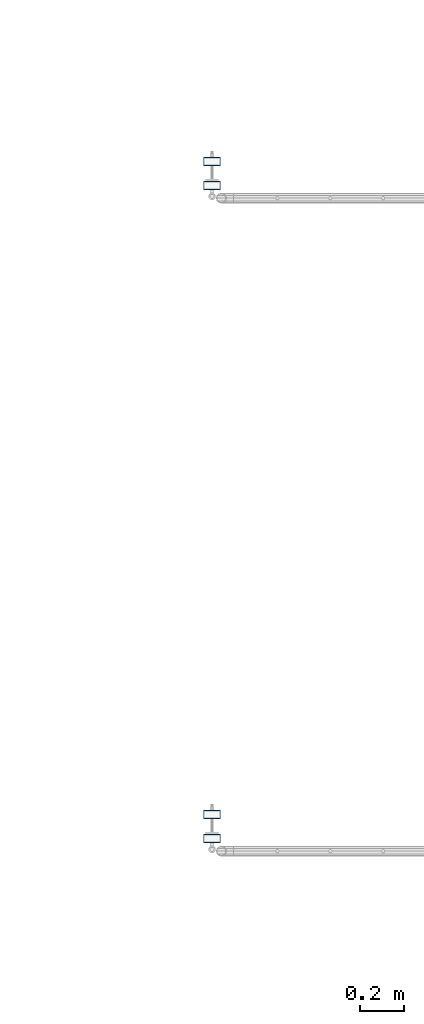
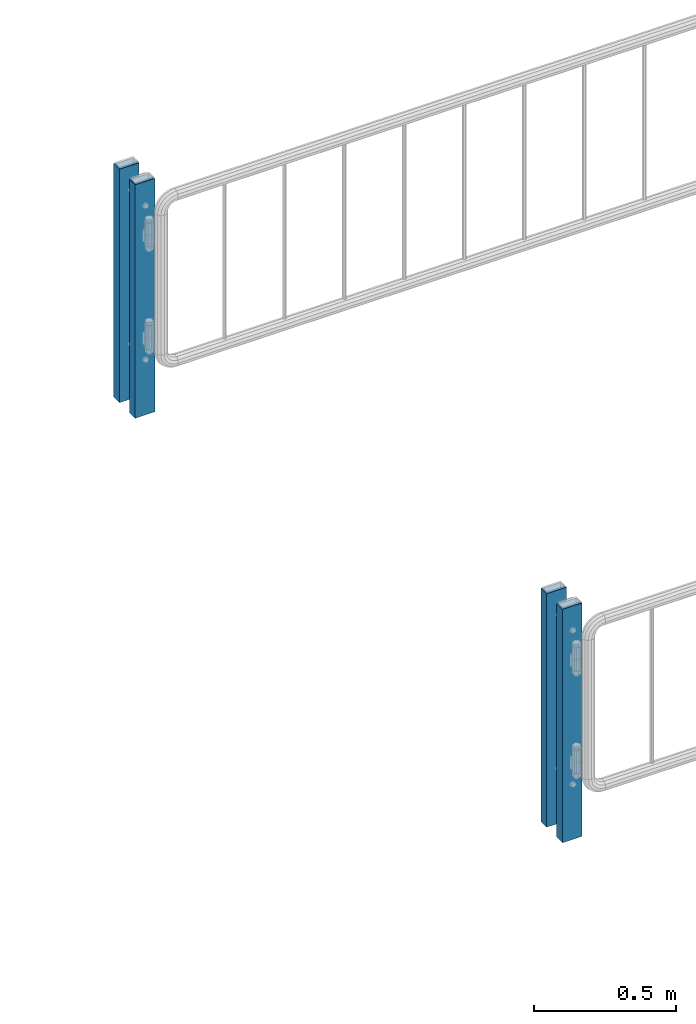
# One storey, part 53 of 208: 4 columns.
"""IFC2X3 building model written with IfcOpenShell, lengths in millimetres."""

from ifc_helpers import new_model, si_unit, frame, origin_with_axes, place, context, subcontext, project, spatial, faceted_brep, material, type_object, element, save


model = new_model("IFC2X3")

# Units and contexts
model_context = context("Model", 3, precision=1e-05, world=origin_with_axes())
body_context = subcontext(model_context, "Body", "Model", "MODEL_VIEW")
ifc_project = project(units=[si_unit("LENGTHUNIT", "METRE", prefix="MILLI"), si_unit("AREAUNIT", "SQUARE_METRE"), si_unit("VOLUMEUNIT", "CUBIC_METRE"), si_unit("MASSUNIT", "GRAM", prefix="KILO"), si_unit("TIMEUNIT", "SECOND"), si_unit("PLANEANGLEUNIT", "RADIAN"), si_unit("SOLIDANGLEUNIT", "STERADIAN"), si_unit("THERMODYNAMICTEMPERATUREUNIT", "DEGREE_CELSIUS"), si_unit("LUMINOUSINTENSITYUNIT", "LUMEN")], contexts=[model_context])

# Site, building, storey
site_placement = place(None, origin_with_axes())
site = spatial("IfcSite", under=ifc_project, at=site_placement, CompositionType="ELEMENT")
building_placement = place(site_placement, origin_with_axes())
building = spatial("IfcBuilding", under=site, at=building_placement, Name="Standard", CompositionType="ELEMENT")
storey_placement = place(building_placement, origin_with_axes())
storey = spatial("IfcBuildingStorey", under=building, at=storey_placement, Name="Undefined", CompositionType="ELEMENT", Elevation=0.0)

# Columns
ifc_material = material()
column_type = type_object("IfcColumnType", PredefinedType="NOTDEFINED")
for number, where, z_axis, x_axis in (
    (1, (-15594.2539827644, 3110.30399999619, 6.54446186132418e-06), (-1.0, 0.0, 0.0), (0.0, 0.0, 1.0)),
    (2, (-15594.2539827644, 3000.0039999962, 6.54446186132418e-06), (-1.0, 0.0, 0.0), (0.0, 0.0, 1.0)),
    (3, (-15594.2539827644, 6110.30399999619, 6.54446186132418e-06), (-1.0, 0.0, 0.0), (0.0, 0.0, 1.0)),
    (4, (-15594.2539827644, 6000.0039999962, 6.54446186132418e-06), (-1.0, 0.0, 0.0), (0.0, 0.0, 1.0)),
):
    element("IfcColumn", number, at=place(storey_placement, frame(where, z_axis=z_axis, x_axis=x_axis)), inside=storey, type_object=column_type, material=ifc_material, context=body_context, shape_type="Brep", body=[
        faceted_brep([(0.0, 16.0, -36.0), (0.0, -16.0, -36.0), (1000.0, -16.0, -36.0), (1000.0, 16.0, -36.0), (0.0, -16.0, 36.0), (1000.0, -16.0, 36.0), (0.0, 16.0, 36.0), (1000.0, 16.0, 36.0), (0.0, 20.0, -40.0), (0.0, 20.0, 40.0), (1000.0, 20.0, 40.0), (1000.0, 20.0, -40.0), (0.0, -20.0, 40.0), (1000.0, -20.0, 40.0), (0.0, -20.0, -40.0), (1000.0, -20.0, -40.0)], [[[0, 1, 2, 3]], [[1, 4, 5, 2]], [[4, 6, 7, 5]], [[6, 0, 3, 7]], [[8, 9, 10, 11]], [[9, 12, 13, 10]], [[12, 14, 15, 13]], [[14, 8, 11, 15]], [[13, 15, 11, 10], [5, 7, 3, 2]], [[14, 12, 9, 8], [6, 4, 1, 0]]]),
    ])

save(model, "model.ifc")
